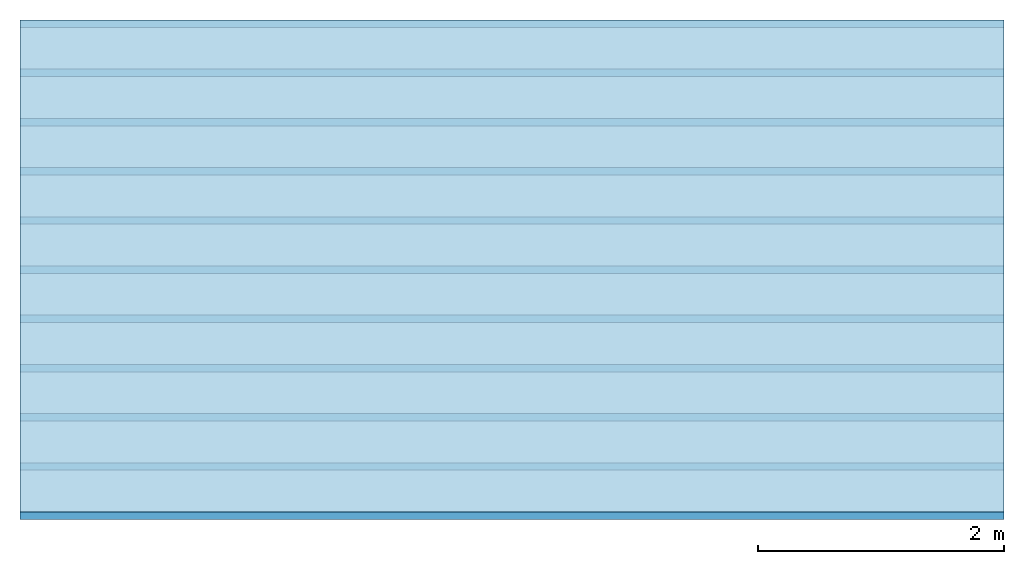
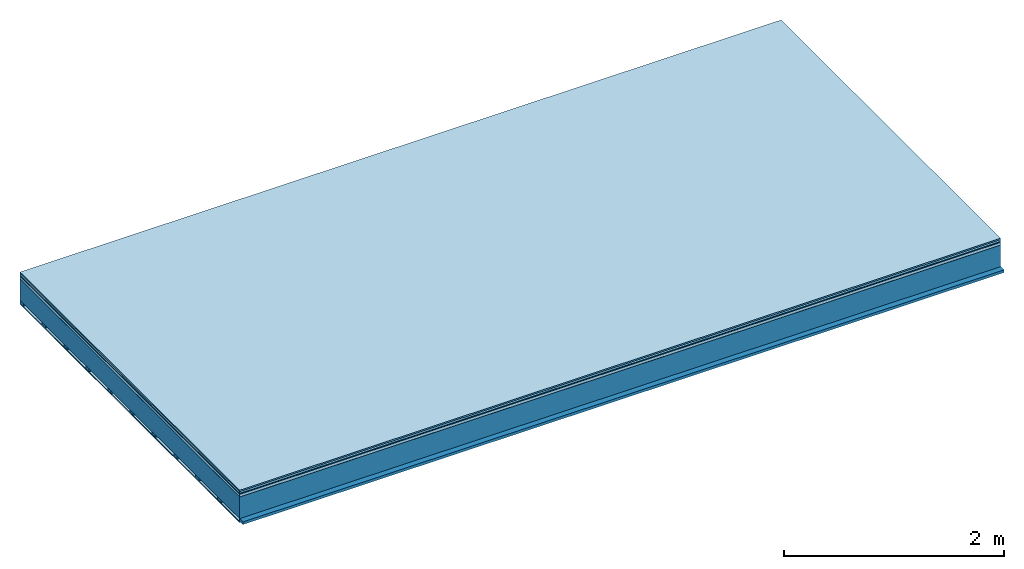
# One storey: 7 plates, 2 members, 1 element without a shape of its own.
"""IFC4 building model written with IfcOpenShell, lengths in metres."""

from ifc_helpers import new_model, si_unit, derived_unit, direction, frame, frame_2d, origin, origin_with_axes, place, context, project, spatial, rectangle, extrude, material, layer, layer_set, type_object, element, aggregate, save


model = new_model("IFC4")

# Units and contexts
plan_context = context("Plan", 3, precision=1e-05, world=origin(), true_north=direction((0.0, 1.0)))
model_context = context("Model", 3, precision=1e-05, world=origin(), true_north=direction((0.0, 1.0)))
ifc_project = project(units=[si_unit("LENGTHUNIT", "METRE"), derived_unit("SOUNDPRESSUREUNIT", [(si_unit("PRESSUREUNIT", "PASCAL", prefix="MICRO"), 0)]), si_unit("ENERGYUNIT", "JOULE", prefix="MEGA"), si_unit("MASSUNIT", "GRAM", prefix="KILO"), derived_unit("THERMALTRANSMITTANCEUNIT", [(si_unit("POWERUNIT", "WATT"), 1), (si_unit("AREAUNIT", "SQUARE_METRE"), -1), (si_unit("THERMODYNAMICTEMPERATUREUNIT", "KELVIN"), -1)]), derived_unit("AREADENSITYUNIT", [(si_unit("MASSUNIT", "GRAM", prefix="KILO"), 1), (si_unit("AREAUNIT", "SQUARE_METRE"), -1)]), derived_unit("USERDEFINED", [(si_unit("ENERGYUNIT", "JOULE", prefix="MEGA"), 1), (si_unit("AREAUNIT", "SQUARE_METRE"), -1)])], contexts=[plan_context, model_context])

# Site, building, storey
site = spatial("IfcSite", under=ifc_project)
building_placement = place(None, origin())
building = spatial("IfcBuilding", under=site, at=building_placement)
storey_placement = place(building_placement, origin())
storey = spatial("IfcBuildingStorey", under=building, at=storey_placement)

# Slab, members, plates
ifc_material_1 = material(Category="11.013")
ifc_layer_1 = layer(ifc_material_1, 0.015, Name="Flooring")
ifc_material_2 = material(Category="03.007")
ifc_layer_2 = layer(ifc_material_2, 0.02, Name="On-material")
ifc_material_3 = material(Name="Wood fiber generic product", Category="10.009")
ifc_layer_3 = layer(ifc_material_3, 0.01, Name="Impact sound insulation")
ifc_material_4 = material(Name="with broken")
ifc_layer_4 = layer(ifc_material_4, 0.03, Name="on Supporting structure")
ifc_material_5 = material(Name="protection", Category="09.007")
ifc_layer_5 = layer(ifc_material_5, 0.0005, Name="Sub-floor")
ifc_material_6 = material(Name="no composite action")
ifc_layer_6 = layer(ifc_material_6, 0.0, Name="Bond")
ifc_layer_7 = layer(None, 0.24, Name="Supporting structure")
ifc_material_7 = material(Name="of the art")
ifc_layer_8 = layer(ifc_material_7, 0.0, Name="Bond")
ifc_layer_9 = layer(None, 0.03, Name="Battens / profiles")
ifc_material_8 = material(Name="Plasterboard type A", Category="03.008")
ifc_layer_10 = layer(ifc_material_8, 0.0125, Name="Ceiling covering 1st layer")
ifc_material_9 = material(Category="04.001")
ifc_layer_11 = layer(ifc_material_9, 0.003, Name="Surface / treatment")
ifc_layer_set = layer_set([ifc_layer_1, ifc_layer_2, ifc_layer_3, ifc_layer_4, ifc_layer_5, ifc_layer_6, ifc_layer_7, ifc_layer_8, ifc_layer_9, ifc_layer_10, ifc_layer_11])
slab_type = type_object("IfcSlabType", Name="A2111", PredefinedType="NOTDEFINED", material=ifc_layer_set)
slab_placement = place(None, frame((0.0, 0.0, 0.0), z_axis=(0.0, 0.0, -1.0), x_axis=(1.0, 0.0, 0.0)))
slab = element("IfcSlab", 1, at=slab_placement, inside=storey, type_object=slab_type, material=ifc_layer_set, Name="Slab #1")
ifc_material_10 = material(Name="Solid timber panel")
member_1_placement = place(slab_placement, origin())
member_1 = element("IfcMember", 2, at=member_1_placement, material=ifc_material_10, Name="Supporting structure", context=plan_context, shape_type="SweptSolid", body=[
    extrude(rectangle(XDim=1.0, YDim=0.24, at=frame_2d((0.5, 0.12), x_axis=(1.0, 0.0))), frame((0.0, 4.0, 0.0755), z_axis=(0.0, -1.0, 0.0), x_axis=(1.0, 0.0, 0.0)), (0.0, 0.0, 1.0), 4.0),
    extrude(rectangle(XDim=1.0, YDim=0.24, at=frame_2d((0.5, 0.12), x_axis=(1.0, 0.0))), frame((1.0, 4.0, 0.0755), z_axis=(0.0, -1.0, 0.0), x_axis=(1.0, 0.0, 0.0)), (0.0, 0.0, 1.0), 4.0),
    extrude(rectangle(XDim=1.0, YDim=0.24, at=frame_2d((0.5, 0.12), x_axis=(1.0, 0.0))), frame((2.0, 4.0, 0.0755), z_axis=(0.0, -1.0, 0.0), x_axis=(1.0, 0.0, 0.0)), (0.0, 0.0, 1.0), 4.0),
    extrude(rectangle(XDim=1.0, YDim=0.24, at=frame_2d((0.5, 0.12), x_axis=(1.0, 0.0))), frame((3.0, 4.0, 0.0755), z_axis=(0.0, -1.0, 0.0), x_axis=(1.0, 0.0, 0.0)), (0.0, 0.0, 1.0), 4.0),
    extrude(rectangle(XDim=1.0, YDim=0.24, at=frame_2d((0.5, 0.12), x_axis=(1.0, 0.0))), frame((4.0, 4.0, 0.0755), z_axis=(0.0, -1.0, 0.0), x_axis=(1.0, 0.0, 0.0)), (0.0, 0.0, 1.0), 4.0),
    extrude(rectangle(XDim=1.0, YDim=0.24, at=frame_2d((0.5, 0.12), x_axis=(1.0, 0.0))), frame((5.0, 4.0, 0.0755), z_axis=(0.0, -1.0, 0.0), x_axis=(1.0, 0.0, 0.0)), (0.0, 0.0, 1.0), 4.0),
    extrude(rectangle(XDim=1.0, YDim=0.24, at=frame_2d((0.5, 0.12), x_axis=(1.0, 0.0))), frame((6.0, 4.0, 0.0755), z_axis=(0.0, -1.0, 0.0), x_axis=(1.0, 0.0, 0.0)), (0.0, 0.0, 1.0), 4.0),
    extrude(rectangle(XDim=1.0, YDim=0.24, at=frame_2d((0.5, 0.12), x_axis=(1.0, 0.0))), frame((7.0, 4.0, 0.0755), z_axis=(0.0, -1.0, 0.0), x_axis=(1.0, 0.0, 0.0)), (0.0, 0.0, 1.0), 4.0),
])
ifc_material_11 = material()
member_2_placement = place(slab_placement, origin())
member_2 = element("IfcMember", 3, at=member_2_placement, material=ifc_material_11, Name="Battens / profiles", context=plan_context, shape_type="SweptSolid", body=[
    extrude(rectangle(XDim=0.06, YDim=0.03, at=frame_2d((0.03, 0.015), x_axis=(1.0, 0.0))), frame((0.0, 0.0, 0.3155), z_axis=(1.0, 0.0, 0.0), x_axis=(0.0, 1.0, 0.0)), (0.0, 0.0, 1.0), 8.0),
    extrude(rectangle(XDim=0.06, YDim=0.03, at=frame_2d((0.03, 0.015), x_axis=(1.0, 0.0))), frame((0.0, 0.4, 0.3155), z_axis=(1.0, 0.0, 0.0), x_axis=(0.0, 1.0, 0.0)), (0.0, 0.0, 1.0), 8.0),
    extrude(rectangle(XDim=0.06, YDim=0.03, at=frame_2d((0.03, 0.015), x_axis=(1.0, 0.0))), frame((0.0, 0.8, 0.3155), z_axis=(1.0, 0.0, 0.0), x_axis=(0.0, 1.0, 0.0)), (0.0, 0.0, 1.0), 8.0),
    extrude(rectangle(XDim=0.06, YDim=0.03, at=frame_2d((0.03, 0.015), x_axis=(1.0, 0.0))), frame((0.0, 1.2, 0.3155), z_axis=(1.0, 0.0, 0.0), x_axis=(0.0, 1.0, 0.0)), (0.0, 0.0, 1.0), 8.0),
    extrude(rectangle(XDim=0.06, YDim=0.03, at=frame_2d((0.03, 0.015), x_axis=(1.0, 0.0))), frame((0.0, 1.6, 0.3155), z_axis=(1.0, 0.0, 0.0), x_axis=(0.0, 1.0, 0.0)), (0.0, 0.0, 1.0), 8.0),
    extrude(rectangle(XDim=0.06, YDim=0.03, at=frame_2d((0.03, 0.015), x_axis=(1.0, 0.0))), frame((0.0, 2.0, 0.3155), z_axis=(1.0, 0.0, 0.0), x_axis=(0.0, 1.0, 0.0)), (0.0, 0.0, 1.0), 8.0),
    extrude(rectangle(XDim=0.06, YDim=0.03, at=frame_2d((0.03, 0.015), x_axis=(1.0, 0.0))), frame((0.0, 2.4, 0.3155), z_axis=(1.0, 0.0, 0.0), x_axis=(0.0, 1.0, 0.0)), (0.0, 0.0, 1.0), 8.0),
    extrude(rectangle(XDim=0.06, YDim=0.03, at=frame_2d((0.03, 0.015), x_axis=(1.0, 0.0))), frame((0.0, 2.8, 0.3155), z_axis=(1.0, 0.0, 0.0), x_axis=(0.0, 1.0, 0.0)), (0.0, 0.0, 1.0), 8.0),
    extrude(rectangle(XDim=0.06, YDim=0.03, at=frame_2d((0.03, 0.015), x_axis=(1.0, 0.0))), frame((0.0, 3.2, 0.3155), z_axis=(1.0, 0.0, 0.0), x_axis=(0.0, 1.0, 0.0)), (0.0, 0.0, 1.0), 8.0),
    extrude(rectangle(XDim=0.06, YDim=0.03, at=frame_2d((0.03, 0.015), x_axis=(1.0, 0.0))), frame((0.0, 3.6, 0.3155), z_axis=(1.0, 0.0, 0.0), x_axis=(0.0, 1.0, 0.0)), (0.0, 0.0, 1.0), 8.0),
    extrude(rectangle(XDim=0.06, YDim=0.03, at=frame_2d((0.03, 0.015), x_axis=(1.0, 0.0))), frame((0.0, 4.0, 0.3155), z_axis=(1.0, 0.0, 0.0), x_axis=(0.0, 1.0, 0.0)), (0.0, 0.0, 1.0), 8.0),
])
plate_1_placement = place(slab_placement, origin())
plate_1 = element("IfcPlate", 4, at=plate_1_placement, material=ifc_material_1, Name="Flooring", context=plan_context, shape_type="SweptSolid", body=[
    extrude(rectangle(XDim=8.0, YDim=4.0, at=frame_2d((4.0, 2.0), x_axis=(1.0, 0.0))), origin_with_axes(), (0.0, 0.0, 1.0), 0.015),
])
plate_2_placement = place(slab_placement, origin())
plate_2 = element("IfcPlate", 5, at=plate_2_placement, material=ifc_material_2, Name="On-material", context=plan_context, shape_type="SweptSolid", body=[
    extrude(rectangle(XDim=8.0, YDim=4.0, at=frame_2d((4.0, 2.0), x_axis=(1.0, 0.0))), frame((0.0, 0.0, 0.015), z_axis=(0.0, 0.0, 1.0), x_axis=(1.0, 0.0, 0.0)), (0.0, 0.0, 1.0), 0.02),
])
plate_3_placement = place(slab_placement, origin())
plate_3 = element("IfcPlate", 6, at=plate_3_placement, material=ifc_material_3, Name="Impact sound insulation", context=plan_context, shape_type="SweptSolid", body=[
    extrude(rectangle(XDim=8.0, YDim=4.0, at=frame_2d((4.0, 2.0), x_axis=(1.0, 0.0))), frame((0.0, 0.0, 0.035), z_axis=(0.0, 0.0, 1.0), x_axis=(1.0, 0.0, 0.0)), (0.0, 0.0, 1.0), 0.01),
])
plate_4_placement = place(slab_placement, origin())
plate_4 = element("IfcPlate", 7, at=plate_4_placement, material=ifc_material_4, Name="on Supporting structure", context=plan_context, shape_type="SweptSolid", body=[
    extrude(rectangle(XDim=8.0, YDim=4.0, at=frame_2d((4.0, 2.0), x_axis=(1.0, 0.0))), frame((0.0, 0.0, 0.045), z_axis=(0.0, 0.0, 1.0), x_axis=(1.0, 0.0, 0.0)), (0.0, 0.0, 1.0), 0.03),
])
plate_5_placement = place(slab_placement, origin())
plate_5 = element("IfcPlate", 8, at=plate_5_placement, material=ifc_material_5, Name="Sub-floor", context=plan_context, shape_type="SweptSolid", body=[
    extrude(rectangle(XDim=8.0, YDim=4.0, at=frame_2d((4.0, 2.0), x_axis=(1.0, 0.0))), frame((0.0, 0.0, 0.075), z_axis=(0.0, 0.0, 1.0), x_axis=(1.0, 0.0, 0.0)), (0.0, 0.0, 1.0), 0.0005),
])
plate_6_placement = place(slab_placement, origin())
plate_6 = element("IfcPlate", 9, at=plate_6_placement, material=ifc_material_8, Name="Ceiling covering 1st layer", context=plan_context, shape_type="SweptSolid", body=[
    extrude(rectangle(XDim=8.0, YDim=4.0, at=frame_2d((4.0, 2.0), x_axis=(1.0, 0.0))), frame((0.0, 0.0, 0.3455), z_axis=(0.0, 0.0, 1.0), x_axis=(1.0, 0.0, 0.0)), (0.0, 0.0, 1.0), 0.0125),
])
plate_7_placement = place(slab_placement, origin())
plate_7 = element("IfcPlate", 10, at=plate_7_placement, material=ifc_material_9, Name="Surface / treatment", context=plan_context, shape_type="SweptSolid", body=[
    extrude(rectangle(XDim=8.0, YDim=4.0, at=frame_2d((4.0, 2.0), x_axis=(1.0, 0.0))), frame((0.0, 0.0, 0.358), z_axis=(0.0, 0.0, 1.0), x_axis=(1.0, 0.0, 0.0)), (0.0, 0.0, 1.0), 0.003),
])
aggregate(slab, [plate_1, plate_2, plate_3, plate_4, plate_5, member_1, member_2, plate_6, plate_7])

save(model, "model.ifc")
